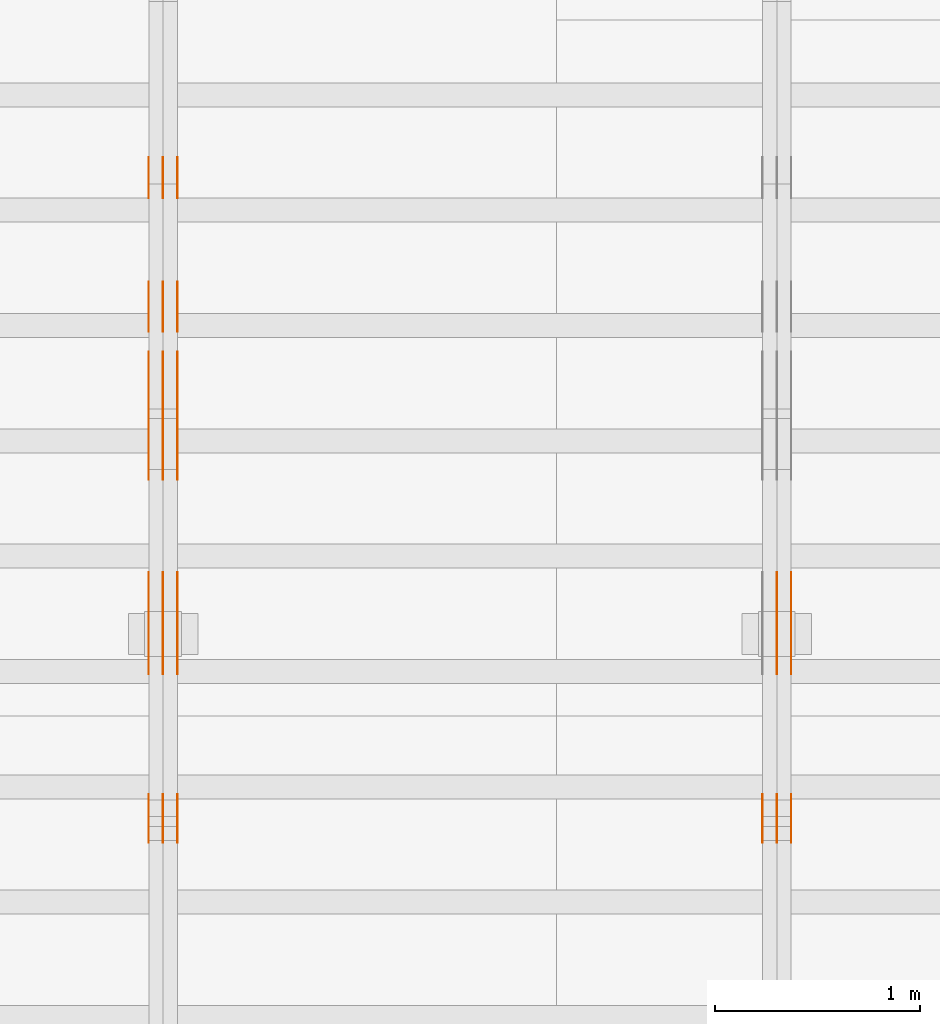
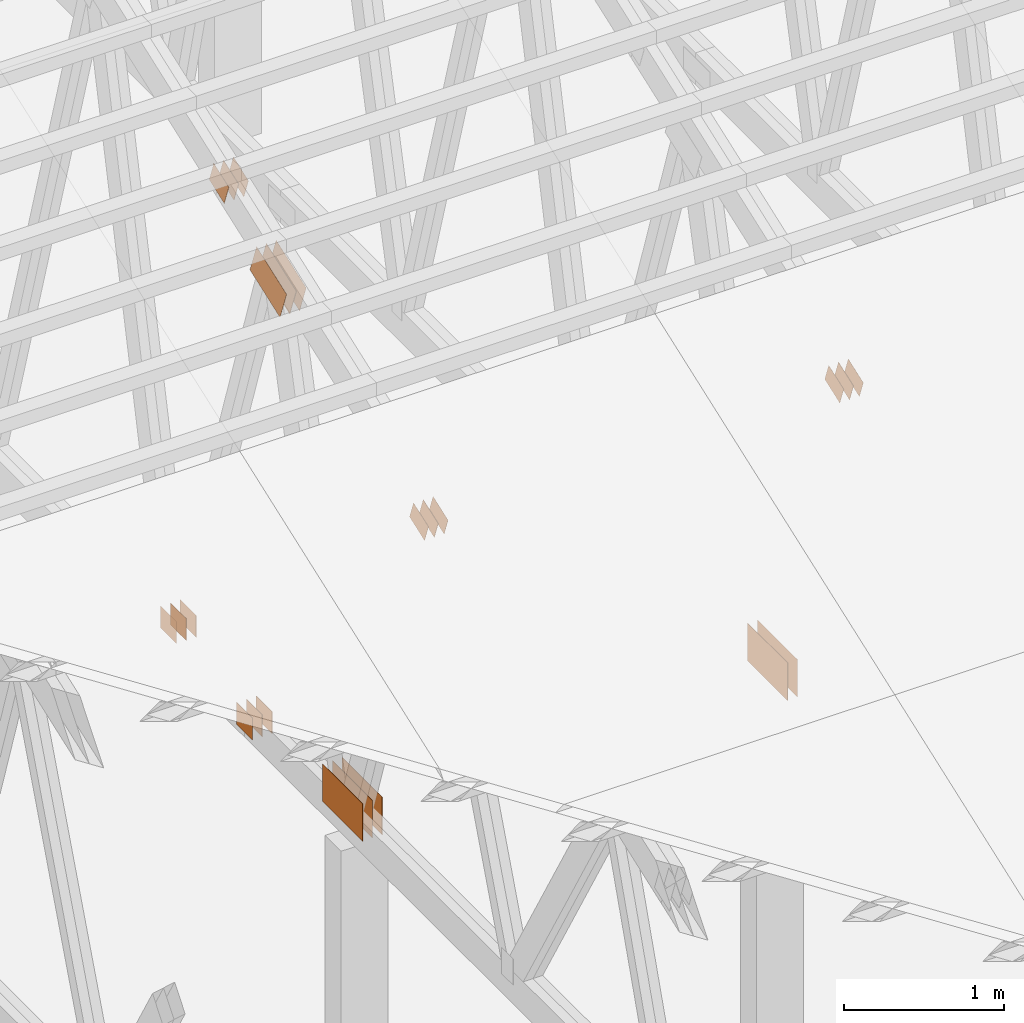
# One storey, part 81 of 189: 31 proxies.
"""IFC2X3 building model written with IfcOpenShell, lengths in millimetres."""

from ifc_helpers import new_model, entity, si_unit, converted_unit, derived_unit, direction, frame, frame_2d, origin, origin_2d_with_axis, place, context, subcontext, project, spatial, polyline, rectangle, outline, extrude, source, transform, mapped, material, type_object, type_shapes, element, save


model = new_model("IFC2X3")

# Units and contexts
model_context = context("Model", 3, precision=0.01, world=origin(), true_north=direction((6.12303176911189e-17, 1.0)))
body_context = subcontext(model_context, "Body", "Model", "MODEL_VIEW")
ifc_project = project(units=[si_unit("LENGTHUNIT", "METRE", prefix="MILLI"), si_unit("AREAUNIT", "SQUARE_METRE"), si_unit("VOLUMEUNIT", "CUBIC_METRE"), converted_unit("PLANEANGLEUNIT", "DEGREE", entity("IfcRatioMeasure", 0.0174532925199433), si_unit("PLANEANGLEUNIT", "RADIAN"), dimensions=[0, 0, 0, 0, 0, 0, 0]), si_unit("MASSUNIT", "GRAM", prefix="KILO"), derived_unit("MASSDENSITYUNIT", [(si_unit("MASSUNIT", "GRAM", prefix="KILO"), 1), (si_unit("LENGTHUNIT", "METRE"), -3)]), si_unit("TIMEUNIT", "SECOND"), si_unit("FREQUENCYUNIT", "HERTZ"), si_unit("THERMODYNAMICTEMPERATUREUNIT", "DEGREE_CELSIUS"), derived_unit("THERMALTRANSMITTANCEUNIT", [(si_unit("MASSUNIT", "GRAM", prefix="KILO"), 1), (si_unit("THERMODYNAMICTEMPERATUREUNIT", "KELVIN"), -1), (si_unit("TIMEUNIT", "SECOND"), -3)]), derived_unit("VOLUMETRICFLOWRATEUNIT", [(si_unit("LENGTHUNIT", "METRE"), 3), (si_unit("TIMEUNIT", "SECOND"), -1)]), si_unit("ELECTRICCURRENTUNIT", "AMPERE"), si_unit("ELECTRICVOLTAGEUNIT", "VOLT"), si_unit("POWERUNIT", "WATT"), si_unit("FORCEUNIT", "NEWTON"), si_unit("ILLUMINANCEUNIT", "LUX"), si_unit("LUMINOUSFLUXUNIT", "LUMEN"), si_unit("LUMINOUSINTENSITYUNIT", "CANDELA"), derived_unit("USERDEFINED", [(si_unit("MASSUNIT", "GRAM", prefix="KILO"), -1), (si_unit("LENGTHUNIT", "METRE"), -2), (si_unit("TIMEUNIT", "SECOND"), 3), (si_unit("LUMINOUSFLUXUNIT", "LUMEN"), 1)]), derived_unit("LINEARVELOCITYUNIT", [(si_unit("LENGTHUNIT", "METRE"), 1), (si_unit("TIMEUNIT", "SECOND"), -1)]), si_unit("PRESSUREUNIT", "PASCAL"), derived_unit("USERDEFINED", [(si_unit("LENGTHUNIT", "METRE"), -2), (si_unit("MASSUNIT", "GRAM", prefix="KILO"), 1), (si_unit("TIMEUNIT", "SECOND"), -2)])], contexts=[model_context])

# Site, building, storey
site_placement = place(None, origin())
site = spatial("IfcSite", under=ifc_project, at=site_placement, CompositionType="ELEMENT")
building_placement = place(site_placement, origin())
building = spatial("IfcBuilding", under=site, at=building_placement, CompositionType="ELEMENT")
storey_placement = place(building_placement, origin())
storey = spatial("IfcBuildingStorey", under=building, at=storey_placement, Name="Default", CompositionType="ELEMENT", Elevation=0.0)

# Proxies
ifc_material_1 = material(Name="IfcSurfaceStyle #76038")
building_element_proxy_type_1 = type_object("IfcBuildingElementProxyType", PredefinedType="NOTDEFINED", material=ifc_material_1)
shared_shape_1 = source(origin(), body_context, "Body", "SweptSolid", [
    extrude(rectangle(XDim=500.0, YDim=288.0, at=frame_2d((0.0, 1.4210854715202e-14), x_axis=(1.0, 0.0))), frame((250.000973740011, 144.0, 0.0), z_axis=(0.0, 0.0, 1.0), x_axis=(-1.0, 0.0, 0.0)), (0.0, 0.0, 1.0), 1.29999999999998),
])
type_shapes(building_element_proxy_type_1, [shared_shape_1])
proxy_1_placement = place(building_placement, frame((12301.3, 8551.90918250999, 389.0), z_axis=(-1.0, 0.0, 0.0), x_axis=(0.0, 1.0, 0.0)))
element("IfcBuildingElementProxy", 1, at=proxy_1_placement, inside=storey, type_object=building_element_proxy_type_1, material=ifc_material_1, context=body_context, shape_type="MappedRepresentation", body=[
    mapped(shared_shape_1, transform((0.0, 0.0, 0.0), scale=1.0)),
])
ifc_material_2 = material(Name="IfcSurfaceStyle #75981")
building_element_proxy_type_2 = type_object("IfcBuildingElementProxyType", PredefinedType="NOTDEFINED", material=ifc_material_2)
shared_shape_2 = source(origin(), body_context, "Body", "SweptSolid", [
    extrude(rectangle(XDim=500.0, YDim=288.0, at=frame_2d((0.0, 1.4210854715202e-14), x_axis=(1.0, 0.0))), frame((250.000973740011, 144.0, 0.0), z_axis=(0.0, 0.0, 1.0), x_axis=(-1.0, 0.0, 0.0)), (0.0, 0.0, 1.0), 1.29999999999997),
])
type_shapes(building_element_proxy_type_2, [shared_shape_2])
proxy_2_placement = place(building_placement, frame((12230.0, 8551.90918250999, 389.0), z_axis=(-1.0, 0.0, 0.0), x_axis=(0.0, 1.0, 0.0)))
element("IfcBuildingElementProxy", 2, at=proxy_2_placement, inside=storey, type_object=building_element_proxy_type_2, material=ifc_material_2, context=body_context, shape_type="MappedRepresentation", body=[
    mapped(shared_shape_2, transform((0.0, 0.0, 0.0), scale=1.0)),
])
ifc_material_3 = material(Name="IfcSurfaceStyle #75924")
building_element_proxy_type_3 = type_object("IfcBuildingElementProxyType", PredefinedType="NOTDEFINED", material=ifc_material_3)
shared_shape_3 = source(origin(), body_context, "Body", "SweptSolid", [
    extrude(rectangle(XDim=500.0, YDim=288.0, at=frame_2d((0.0, 1.4210854715202e-14), x_axis=(1.0, 0.0))), frame((250.000973740011, 144.0, 0.0), z_axis=(0.0, 0.0, 1.0), x_axis=(-1.0, 0.0, 0.0)), (0.0, 0.0, 1.0), 1.29999999999997),
])
type_shapes(building_element_proxy_type_3, [shared_shape_3])
proxy_3_placement = place(building_placement, frame((12231.3, 8551.90918250999, 389.0), z_axis=(-1.0, 0.0, 0.0), x_axis=(0.0, 1.0, 0.0)))
element("IfcBuildingElementProxy", 3, at=proxy_3_placement, inside=storey, type_object=building_element_proxy_type_3, material=ifc_material_3, context=body_context, shape_type="MappedRepresentation", body=[
    mapped(shared_shape_3, transform((0.0, 0.0, 0.0), scale=1.0)),
])
ifc_material_4 = material(Name="IfcSurfaceStyle #75810")
building_element_proxy_type_4 = type_object("IfcBuildingElementProxyType", PredefinedType="NOTDEFINED", material=ifc_material_4)
shared_shape_4 = source(origin(), body_context, "Body", "SweptSolid", [
    extrude(outline(polyline([(-100.00048713087, -72.0000025659129), (100.000394045495, -72.0000025659129), (99.9995694622958, 72.0000025659129), (-99.9994763769209, 72.0000025659128), (-100.00048713087, -72.0000025659129)])), frame((100.000394045495, 72.0000025659128, 0.0), z_axis=(0.0, 0.0, 1.0), x_axis=(-1.0, 0.0, 0.0)), (0.0, 0.0, 1.0), 1.3),
])
type_shapes(building_element_proxy_type_4, [shared_shape_4])
proxy_4_placement = place(building_placement, frame((12301.3, 7965.16887114408, 2936.19963864386), z_axis=(-1.0, 0.0, 0.0), x_axis=(0.0, -0.939692620785908, -0.342020143325669)))
element("IfcBuildingElementProxy", 4, at=proxy_4_placement, inside=storey, type_object=building_element_proxy_type_4, material=ifc_material_4, context=body_context, shape_type="MappedRepresentation", body=[
    mapped(shared_shape_4, transform((0.0, 0.0, 0.0), scale=1.0)),
])
ifc_material_5 = material(Name="IfcSurfaceStyle #75753")
building_element_proxy_type_5 = type_object("IfcBuildingElementProxyType", PredefinedType="NOTDEFINED", material=ifc_material_5)
shared_shape_5 = source(origin(), body_context, "Body", "SweptSolid", [
    extrude(outline(polyline([(-100.00048713087, -72.0000025659129), (100.000394045495, -72.0000025659129), (99.9995694622958, 72.0000025659129), (-99.9994763769209, 72.0000025659128), (-100.00048713087, -72.0000025659129)])), frame((100.000394045495, 72.0000025659128, 0.0), z_axis=(0.0, 0.0, 1.0), x_axis=(-1.0, 0.0, 0.0)), (0.0, 0.0, 1.0), 1.29999999999998),
])
type_shapes(building_element_proxy_type_5, [shared_shape_5])
proxy_5_placement = place(building_placement, frame((12230.0, 7965.16887114408, 2936.19963864386), z_axis=(-1.0, 0.0, 0.0), x_axis=(0.0, -0.939692620785908, -0.342020143325669)))
element("IfcBuildingElementProxy", 5, at=proxy_5_placement, inside=storey, type_object=building_element_proxy_type_5, material=ifc_material_5, context=body_context, shape_type="MappedRepresentation", body=[
    mapped(shared_shape_5, transform((0.0, 0.0, 0.0), scale=1.0)),
])
ifc_material_6 = material(Name="IfcSurfaceStyle #75696")
building_element_proxy_type_6 = type_object("IfcBuildingElementProxyType", PredefinedType="NOTDEFINED", material=ifc_material_6)
shared_shape_6 = source(origin(), body_context, "Body", "SweptSolid", [
    extrude(outline(polyline([(-100.00048713087, -72.0000025659129), (100.000394045495, -72.0000025659129), (99.9995694622958, 72.0000025659129), (-99.9994763769209, 72.0000025659128), (-100.00048713087, -72.0000025659129)])), frame((100.000394045495, 72.0000025659128, 0.0), z_axis=(0.0, 0.0, 1.0), x_axis=(-1.0, 0.0, 0.0)), (0.0, 0.0, 1.0), 1.29999999999998),
])
type_shapes(building_element_proxy_type_6, [shared_shape_6])
proxy_6_placement = place(building_placement, frame((12231.3, 7965.16887114408, 2936.19963864386), z_axis=(-1.0, 0.0, 0.0), x_axis=(0.0, -0.939692620785908, -0.342020143325669)))
element("IfcBuildingElementProxy", 6, at=proxy_6_placement, inside=storey, type_object=building_element_proxy_type_6, material=ifc_material_6, context=body_context, shape_type="MappedRepresentation", body=[
    mapped(shared_shape_6, transform((0.0, 0.0, 0.0), scale=1.0)),
])
ifc_material_7 = material(Name="IfcSurfaceStyle #75639")
building_element_proxy_type_7 = type_object("IfcBuildingElementProxyType", PredefinedType="NOTDEFINED", material=ifc_material_7)
shared_shape_7 = source(origin(), body_context, "Body", "SweptSolid", [
    extrude(outline(polyline([(-100.00048713087, -72.0000025659129), (100.000394045495, -72.0000025659129), (99.9995694622958, 72.0000025659129), (-99.9994763769209, 72.0000025659128), (-100.00048713087, -72.0000025659129)])), frame((100.000394045495, 72.0000025659128, 0.0), z_axis=(0.0, 0.0, 1.0), x_axis=(-1.0, 0.0, 0.0)), (0.0, 0.0, 1.0), 1.29999999999999),
])
type_shapes(building_element_proxy_type_7, [shared_shape_7])
proxy_7_placement = place(building_placement, frame((12160.0, 7965.16887114408, 2936.19963864386), z_axis=(-1.0, 0.0, 0.0), x_axis=(0.0, -0.939692620785908, -0.342020143325669)))
element("IfcBuildingElementProxy", 7, at=proxy_7_placement, inside=storey, type_object=building_element_proxy_type_7, material=ifc_material_7, context=body_context, shape_type="MappedRepresentation", body=[
    mapped(shared_shape_7, transform((0.0, 0.0, 0.0), scale=1.0)),
])
ifc_material_8 = material(Name="IfcSurfaceStyle #61160")
building_element_proxy_type_8 = type_object("IfcBuildingElementProxyType", PredefinedType="NOTDEFINED", material=ifc_material_8)
shared_shape_8 = source(origin(), body_context, "Body", "SweptSolid", [
    extrude(rectangle(XDim=200.0, YDim=168.0, at=origin_2d_with_axis()), frame((100.000765376775, 84.0, 0.0), z_axis=(0.0, 0.0, 1.0), x_axis=(-1.0, 0.0, 0.0)), (0.0, 0.0, 1.0), 1.3),
])
type_shapes(building_element_proxy_type_8, [shared_shape_8])
proxy_8_placement = place(building_placement, frame((9301.3, 10880.1574377482, 365.0), z_axis=(-1.0, 0.0, 0.0), x_axis=(0.0, 1.0, 0.0)))
element("IfcBuildingElementProxy", 8, at=proxy_8_placement, inside=storey, type_object=building_element_proxy_type_8, material=ifc_material_8, context=body_context, shape_type="MappedRepresentation", body=[
    mapped(shared_shape_8, transform((0.0, 0.0, 0.0), scale=1.0)),
])
ifc_material_9 = material(Name="IfcSurfaceStyle #61103")
building_element_proxy_type_9 = type_object("IfcBuildingElementProxyType", PredefinedType="NOTDEFINED", material=ifc_material_9)
shared_shape_9 = source(origin(), body_context, "Body", "SweptSolid", [
    extrude(rectangle(XDim=200.0, YDim=168.0, at=origin_2d_with_axis()), frame((100.000765376775, 84.0, 0.0), z_axis=(0.0, 0.0, 1.0), x_axis=(-1.0, 0.0, 0.0)), (0.0, 0.0, 1.0), 1.29999999999998),
])
type_shapes(building_element_proxy_type_9, [shared_shape_9])
proxy_9_placement = place(building_placement, frame((9230.0, 10880.1574377482, 365.0), z_axis=(-1.0, 0.0, 0.0), x_axis=(0.0, 1.0, 0.0)))
element("IfcBuildingElementProxy", 9, at=proxy_9_placement, inside=storey, type_object=building_element_proxy_type_9, material=ifc_material_9, context=body_context, shape_type="MappedRepresentation", body=[
    mapped(shared_shape_9, transform((0.0, 0.0, 0.0), scale=1.0)),
])
ifc_material_10 = material(Name="IfcSurfaceStyle #61046")
building_element_proxy_type_10 = type_object("IfcBuildingElementProxyType", PredefinedType="NOTDEFINED", material=ifc_material_10)
shared_shape_10 = source(origin(), body_context, "Body", "SweptSolid", [
    extrude(rectangle(XDim=200.0, YDim=168.0, at=origin_2d_with_axis()), frame((100.000765376775, 84.0, 0.0), z_axis=(0.0, 0.0, 1.0), x_axis=(-1.0, 0.0, 0.0)), (0.0, 0.0, 1.0), 1.29999999999998),
])
type_shapes(building_element_proxy_type_10, [shared_shape_10])
proxy_10_placement = place(building_placement, frame((9231.3, 10880.1574377482, 365.0), z_axis=(-1.0, 0.0, 0.0), x_axis=(0.0, 1.0, 0.0)))
element("IfcBuildingElementProxy", 10, at=proxy_10_placement, inside=storey, type_object=building_element_proxy_type_10, material=ifc_material_10, context=body_context, shape_type="MappedRepresentation", body=[
    mapped(shared_shape_10, transform((0.0, 0.0, 0.0), scale=1.0)),
])
ifc_material_11 = material(Name="IfcSurfaceStyle #60989")
building_element_proxy_type_11 = type_object("IfcBuildingElementProxyType", PredefinedType="NOTDEFINED", material=ifc_material_11)
shared_shape_11 = source(origin(), body_context, "Body", "SweptSolid", [
    extrude(rectangle(XDim=200.0, YDim=168.0, at=origin_2d_with_axis()), frame((100.000765376775, 84.0, 0.0), z_axis=(0.0, 0.0, 1.0), x_axis=(-1.0, 0.0, 0.0)), (0.0, 0.0, 1.0), 1.29999999999999),
])
type_shapes(building_element_proxy_type_11, [shared_shape_11])
proxy_11_placement = place(building_placement, frame((9160.0, 10880.1574377482, 365.0), z_axis=(-1.0, 0.0, 0.0), x_axis=(0.0, 1.0, 0.0)))
element("IfcBuildingElementProxy", 11, at=proxy_11_placement, inside=storey, type_object=building_element_proxy_type_11, material=ifc_material_11, context=body_context, shape_type="MappedRepresentation", body=[
    mapped(shared_shape_11, transform((0.0, 0.0, 0.0), scale=1.0)),
])
ifc_material_12 = material(Name="IfcSurfaceStyle #60932")
building_element_proxy_type_12 = type_object("IfcBuildingElementProxyType", PredefinedType="NOTDEFINED", material=ifc_material_12)
shared_shape_12 = source(origin(), body_context, "Body", "SweptSolid", [
    extrude(outline(polyline([(-199.999582244654, -119.99984375717), (200.000344770932, -119.99984375717), (199.999582244655, 119.99984375717), (-200.000344770934, 119.99984375717), (-199.999582244654, -119.99984375717)])), frame((200.000344770932, 120.0000091947, 0.0), z_axis=(0.0, 0.0, 1.0), x_axis=(-1.0, 0.0, 0.0)), (0.0, 0.0, 1.0), 1.29999999999999),
])
type_shapes(building_element_proxy_type_12, [shared_shape_12])
proxy_12_placement = place(building_placement, frame((9301.3, 9961.90704972973, 3612.2451494258), z_axis=(-1.0, 0.0, 0.0), x_axis=(0.0, -0.939692620785908, -0.342020143325669)))
element("IfcBuildingElementProxy", 12, at=proxy_12_placement, inside=storey, type_object=building_element_proxy_type_12, material=ifc_material_12, context=body_context, shape_type="MappedRepresentation", body=[
    mapped(shared_shape_12, transform((0.0, 0.0, 0.0), scale=1.0)),
])
ifc_material_13 = material(Name="IfcSurfaceStyle #60875")
building_element_proxy_type_13 = type_object("IfcBuildingElementProxyType", PredefinedType="NOTDEFINED", material=ifc_material_13)
shared_shape_13 = source(origin(), body_context, "Body", "SweptSolid", [
    extrude(outline(polyline([(-199.999582244654, -119.99984375717), (200.000344770932, -119.99984375717), (199.999582244655, 119.99984375717), (-200.000344770934, 119.99984375717), (-199.999582244654, -119.99984375717)])), frame((200.000344770932, 120.0000091947, 0.0), z_axis=(0.0, 0.0, 1.0), x_axis=(-1.0, 0.0, 0.0)), (0.0, 0.0, 1.0), 1.29999999999997),
])
type_shapes(building_element_proxy_type_13, [shared_shape_13])
proxy_13_placement = place(building_placement, frame((9230.0, 9961.90704972973, 3612.2451494258), z_axis=(-1.0, 0.0, 0.0), x_axis=(0.0, -0.939692620785908, -0.342020143325669)))
element("IfcBuildingElementProxy", 13, at=proxy_13_placement, inside=storey, type_object=building_element_proxy_type_13, material=ifc_material_13, context=body_context, shape_type="MappedRepresentation", body=[
    mapped(shared_shape_13, transform((0.0, 0.0, 0.0), scale=1.0)),
])
ifc_material_14 = material(Name="IfcSurfaceStyle #60818")
building_element_proxy_type_14 = type_object("IfcBuildingElementProxyType", PredefinedType="NOTDEFINED", material=ifc_material_14)
shared_shape_14 = source(origin(), body_context, "Body", "SweptSolid", [
    extrude(outline(polyline([(-199.999582244654, -119.99984375717), (200.000344770932, -119.99984375717), (199.999582244655, 119.99984375717), (-200.000344770934, 119.99984375717), (-199.999582244654, -119.99984375717)])), frame((200.000344770932, 120.0000091947, 0.0), z_axis=(0.0, 0.0, 1.0), x_axis=(-1.0, 0.0, 0.0)), (0.0, 0.0, 1.0), 1.29999999999997),
])
type_shapes(building_element_proxy_type_14, [shared_shape_14])
proxy_14_placement = place(building_placement, frame((9231.3, 9961.90704972973, 3612.2451494258), z_axis=(-1.0, 0.0, 0.0), x_axis=(0.0, -0.939692620785908, -0.342020143325669)))
element("IfcBuildingElementProxy", 14, at=proxy_14_placement, inside=storey, type_object=building_element_proxy_type_14, material=ifc_material_14, context=body_context, shape_type="MappedRepresentation", body=[
    mapped(shared_shape_14, transform((0.0, 0.0, 0.0), scale=1.0)),
])
ifc_material_15 = material(Name="IfcSurfaceStyle #60761")
building_element_proxy_type_15 = type_object("IfcBuildingElementProxyType", PredefinedType="NOTDEFINED", material=ifc_material_15)
shared_shape_15 = source(origin(), body_context, "Body", "SweptSolid", [
    extrude(outline(polyline([(-199.999582244654, -119.99984375717), (200.000344770932, -119.99984375717), (199.999582244655, 119.99984375717), (-200.000344770934, 119.99984375717), (-199.999582244654, -119.99984375717)])), frame((200.000344770932, 120.0000091947, 0.0), z_axis=(0.0, 0.0, 1.0), x_axis=(-1.0, 0.0, 0.0)), (0.0, 0.0, 1.0), 1.29999999999998),
])
type_shapes(building_element_proxy_type_15, [shared_shape_15])
proxy_15_placement = place(building_placement, frame((9160.0, 9961.90704972973, 3612.2451494258), z_axis=(-1.0, 0.0, 0.0), x_axis=(0.0, -0.939692620785908, -0.342020143325669)))
element("IfcBuildingElementProxy", 15, at=proxy_15_placement, inside=storey, type_object=building_element_proxy_type_15, material=ifc_material_15, context=body_context, shape_type="MappedRepresentation", body=[
    mapped(shared_shape_15, transform((0.0, 0.0, 0.0), scale=1.0)),
])
ifc_material_16 = material(Name="IfcSurfaceStyle #60248")
building_element_proxy_type_16 = type_object("IfcBuildingElementProxyType", PredefinedType="NOTDEFINED", material=ifc_material_16)
shared_shape_16 = source(origin(), body_context, "Body", "SweptSolid", [
    extrude(rectangle(XDim=500.0, YDim=288.0, at=frame_2d((0.0, 1.4210854715202e-14), x_axis=(1.0, 0.0))), frame((250.000973740011, 144.0, 0.0), z_axis=(0.0, 0.0, 1.0), x_axis=(-1.0, 0.0, 0.0)), (0.0, 0.0, 1.0), 1.29999999999998),
])
type_shapes(building_element_proxy_type_16, [shared_shape_16])
proxy_16_placement = place(building_placement, frame((9301.3, 8551.90918250999, 389.0), z_axis=(-1.0, 0.0, 0.0), x_axis=(0.0, 1.0, 0.0)))
element("IfcBuildingElementProxy", 16, at=proxy_16_placement, inside=storey, type_object=building_element_proxy_type_16, material=ifc_material_16, context=body_context, shape_type="MappedRepresentation", body=[
    mapped(shared_shape_16, transform((0.0, 0.0, 0.0), scale=1.0)),
])
ifc_material_17 = material(Name="IfcSurfaceStyle #60191")
building_element_proxy_type_17 = type_object("IfcBuildingElementProxyType", PredefinedType="NOTDEFINED", material=ifc_material_17)
shared_shape_17 = source(origin(), body_context, "Body", "SweptSolid", [
    extrude(rectangle(XDim=500.0, YDim=288.0, at=frame_2d((0.0, 1.4210854715202e-14), x_axis=(1.0, 0.0))), frame((250.000973740011, 144.0, 0.0), z_axis=(0.0, 0.0, 1.0), x_axis=(-1.0, 0.0, 0.0)), (0.0, 0.0, 1.0), 1.29999999999997),
])
type_shapes(building_element_proxy_type_17, [shared_shape_17])
proxy_17_placement = place(building_placement, frame((9230.0, 8551.90918250999, 389.0), z_axis=(-1.0, 0.0, 0.0), x_axis=(0.0, 1.0, 0.0)))
element("IfcBuildingElementProxy", 17, at=proxy_17_placement, inside=storey, type_object=building_element_proxy_type_17, material=ifc_material_17, context=body_context, shape_type="MappedRepresentation", body=[
    mapped(shared_shape_17, transform((0.0, 0.0, 0.0), scale=1.0)),
])
ifc_material_18 = material(Name="IfcSurfaceStyle #60134")
building_element_proxy_type_18 = type_object("IfcBuildingElementProxyType", PredefinedType="NOTDEFINED", material=ifc_material_18)
shared_shape_18 = source(origin(), body_context, "Body", "SweptSolid", [
    extrude(rectangle(XDim=500.0, YDim=288.0, at=frame_2d((0.0, 1.4210854715202e-14), x_axis=(1.0, 0.0))), frame((250.000973740011, 144.0, 0.0), z_axis=(0.0, 0.0, 1.0), x_axis=(-1.0, 0.0, 0.0)), (0.0, 0.0, 1.0), 1.29999999999997),
])
type_shapes(building_element_proxy_type_18, [shared_shape_18])
proxy_18_placement = place(building_placement, frame((9231.3, 8551.90918250999, 389.0), z_axis=(-1.0, 0.0, 0.0), x_axis=(0.0, 1.0, 0.0)))
element("IfcBuildingElementProxy", 18, at=proxy_18_placement, inside=storey, type_object=building_element_proxy_type_18, material=ifc_material_18, context=body_context, shape_type="MappedRepresentation", body=[
    mapped(shared_shape_18, transform((0.0, 0.0, 0.0), scale=1.0)),
])
ifc_material_19 = material(Name="IfcSurfaceStyle #60077")
building_element_proxy_type_19 = type_object("IfcBuildingElementProxyType", PredefinedType="NOTDEFINED", material=ifc_material_19)
shared_shape_19 = source(origin(), body_context, "Body", "SweptSolid", [
    extrude(rectangle(XDim=500.0, YDim=288.0, at=frame_2d((0.0, 1.4210854715202e-14), x_axis=(1.0, 0.0))), frame((250.000973740011, 144.0, 0.0), z_axis=(0.0, 0.0, 1.0), x_axis=(-1.0, 0.0, 0.0)), (0.0, 0.0, 1.0), 1.29999999999997),
])
type_shapes(building_element_proxy_type_19, [shared_shape_19])
proxy_19_placement = place(building_placement, frame((9160.0, 8551.90918250999, 389.0), z_axis=(-1.0, 0.0, 0.0), x_axis=(0.0, 1.0, 0.0)))
element("IfcBuildingElementProxy", 19, at=proxy_19_placement, inside=storey, type_object=building_element_proxy_type_19, material=ifc_material_19, context=body_context, shape_type="MappedRepresentation", body=[
    mapped(shared_shape_19, transform((0.0, 0.0, 0.0), scale=1.0)),
])
ifc_material_20 = material(Name="IfcSurfaceStyle #60020")
building_element_proxy_type_20 = type_object("IfcBuildingElementProxyType", PredefinedType="NOTDEFINED", material=ifc_material_20)
shared_shape_20 = source(origin(), body_context, "Body", "SweptSolid", [
    extrude(outline(polyline([(-100.00048713087, -72.0000025659129), (100.000394045495, -72.0000025659129), (99.9995694622958, 72.0000025659129), (-99.9994763769209, 72.0000025659128), (-100.00048713087, -72.0000025659129)])), frame((100.000394045495, 72.0000025659128, 0.0), z_axis=(0.0, 0.0, 1.0), x_axis=(-1.0, 0.0, 0.0)), (0.0, 0.0, 1.0), 1.3),
])
type_shapes(building_element_proxy_type_20, [shared_shape_20])
proxy_20_placement = place(building_placement, frame((9301.3, 7965.16887114408, 2936.19963864386), z_axis=(-1.0, 0.0, 0.0), x_axis=(0.0, -0.939692620785908, -0.342020143325669)))
element("IfcBuildingElementProxy", 20, at=proxy_20_placement, inside=storey, type_object=building_element_proxy_type_20, material=ifc_material_20, context=body_context, shape_type="MappedRepresentation", body=[
    mapped(shared_shape_20, transform((0.0, 0.0, 0.0), scale=1.0)),
])
ifc_material_21 = material(Name="IfcSurfaceStyle #59963")
building_element_proxy_type_21 = type_object("IfcBuildingElementProxyType", PredefinedType="NOTDEFINED", material=ifc_material_21)
shared_shape_21 = source(origin(), body_context, "Body", "SweptSolid", [
    extrude(outline(polyline([(-100.00048713087, -72.0000025659129), (100.000394045495, -72.0000025659129), (99.9995694622958, 72.0000025659129), (-99.9994763769209, 72.0000025659128), (-100.00048713087, -72.0000025659129)])), frame((100.000394045495, 72.0000025659128, 0.0), z_axis=(0.0, 0.0, 1.0), x_axis=(-1.0, 0.0, 0.0)), (0.0, 0.0, 1.0), 1.29999999999998),
])
type_shapes(building_element_proxy_type_21, [shared_shape_21])
proxy_21_placement = place(building_placement, frame((9230.0, 7965.16887114408, 2936.19963864386), z_axis=(-1.0, 0.0, 0.0), x_axis=(0.0, -0.939692620785908, -0.342020143325669)))
element("IfcBuildingElementProxy", 21, at=proxy_21_placement, inside=storey, type_object=building_element_proxy_type_21, material=ifc_material_21, context=body_context, shape_type="MappedRepresentation", body=[
    mapped(shared_shape_21, transform((0.0, 0.0, 0.0), scale=1.0)),
])
ifc_material_22 = material(Name="IfcSurfaceStyle #59906")
building_element_proxy_type_22 = type_object("IfcBuildingElementProxyType", PredefinedType="NOTDEFINED", material=ifc_material_22)
shared_shape_22 = source(origin(), body_context, "Body", "SweptSolid", [
    extrude(outline(polyline([(-100.00048713087, -72.0000025659129), (100.000394045495, -72.0000025659129), (99.9995694622958, 72.0000025659129), (-99.9994763769209, 72.0000025659128), (-100.00048713087, -72.0000025659129)])), frame((100.000394045495, 72.0000025659128, 0.0), z_axis=(0.0, 0.0, 1.0), x_axis=(-1.0, 0.0, 0.0)), (0.0, 0.0, 1.0), 1.29999999999998),
])
type_shapes(building_element_proxy_type_22, [shared_shape_22])
proxy_22_placement = place(building_placement, frame((9231.3, 7965.16887114408, 2936.19963864386), z_axis=(-1.0, 0.0, 0.0), x_axis=(0.0, -0.939692620785908, -0.342020143325669)))
element("IfcBuildingElementProxy", 22, at=proxy_22_placement, inside=storey, type_object=building_element_proxy_type_22, material=ifc_material_22, context=body_context, shape_type="MappedRepresentation", body=[
    mapped(shared_shape_22, transform((0.0, 0.0, 0.0), scale=1.0)),
])
ifc_material_23 = material(Name="IfcSurfaceStyle #59849")
building_element_proxy_type_23 = type_object("IfcBuildingElementProxyType", PredefinedType="NOTDEFINED", material=ifc_material_23)
shared_shape_23 = source(origin(), body_context, "Body", "SweptSolid", [
    extrude(outline(polyline([(-100.00048713087, -72.0000025659129), (100.000394045495, -72.0000025659129), (99.9995694622958, 72.0000025659129), (-99.9994763769209, 72.0000025659128), (-100.00048713087, -72.0000025659129)])), frame((100.000394045495, 72.0000025659128, 0.0), z_axis=(0.0, 0.0, 1.0), x_axis=(-1.0, 0.0, 0.0)), (0.0, 0.0, 1.0), 1.29999999999999),
])
type_shapes(building_element_proxy_type_23, [shared_shape_23])
proxy_23_placement = place(building_placement, frame((9160.0, 7965.16887114408, 2936.19963864386), z_axis=(-1.0, 0.0, 0.0), x_axis=(0.0, -0.939692620785908, -0.342020143325669)))
element("IfcBuildingElementProxy", 23, at=proxy_23_placement, inside=storey, type_object=building_element_proxy_type_23, material=ifc_material_23, context=body_context, shape_type="MappedRepresentation", body=[
    mapped(shared_shape_23, transform((0.0, 0.0, 0.0), scale=1.0)),
])
ifc_material_24 = material(Name="IfcSurfaceStyle #54608")
building_element_proxy_type_24 = type_object("IfcBuildingElementProxyType", PredefinedType="NOTDEFINED", material=ifc_material_24)
shared_shape_24 = source(origin(), body_context, "Body", "SweptSolid", [
    extrude(rectangle(XDim=200.0, YDim=168.0, at=origin_2d_with_axis()), frame((100.0, 84.0, 0.0), z_axis=(0.0, 0.0, 1.0), x_axis=(-1.0, 0.0, 0.0)), (0.0, 0.0, 1.0), 1.3),
])
type_shapes(building_element_proxy_type_24, [shared_shape_24])
proxy_24_placement = place(building_placement, frame((9301.3, 9929.23046875, 206.5), z_axis=(-1.0, 0.0, 0.0), x_axis=(0.0, 1.0, 0.0)))
element("IfcBuildingElementProxy", 24, at=proxy_24_placement, inside=storey, type_object=building_element_proxy_type_24, material=ifc_material_24, context=body_context, shape_type="MappedRepresentation", body=[
    mapped(shared_shape_24, transform((0.0, 0.0, 0.0), scale=1.0)),
])
ifc_material_25 = material(Name="IfcSurfaceStyle #54551")
building_element_proxy_type_25 = type_object("IfcBuildingElementProxyType", PredefinedType="NOTDEFINED", material=ifc_material_25)
shared_shape_25 = source(origin(), body_context, "Body", "SweptSolid", [
    extrude(rectangle(XDim=200.0, YDim=168.0, at=origin_2d_with_axis()), frame((100.0, 84.0, 0.0), z_axis=(0.0, 0.0, 1.0), x_axis=(-1.0, 0.0, 0.0)), (0.0, 0.0, 1.0), 1.29999999999998),
])
type_shapes(building_element_proxy_type_25, [shared_shape_25])
proxy_25_placement = place(building_placement, frame((9230.0, 9929.23046875, 206.5), z_axis=(-1.0, 0.0, 0.0), x_axis=(0.0, 1.0, 0.0)))
element("IfcBuildingElementProxy", 25, at=proxy_25_placement, inside=storey, type_object=building_element_proxy_type_25, material=ifc_material_25, context=body_context, shape_type="MappedRepresentation", body=[
    mapped(shared_shape_25, transform((0.0, 0.0, 0.0), scale=1.0)),
])
ifc_material_26 = material(Name="IfcSurfaceStyle #54494")
building_element_proxy_type_26 = type_object("IfcBuildingElementProxyType", PredefinedType="NOTDEFINED", material=ifc_material_26)
shared_shape_26 = source(origin(), body_context, "Body", "SweptSolid", [
    extrude(rectangle(XDim=200.0, YDim=168.0, at=origin_2d_with_axis()), frame((100.0, 84.0, 0.0), z_axis=(0.0, 0.0, 1.0), x_axis=(-1.0, 0.0, 0.0)), (0.0, 0.0, 1.0), 1.29999999999998),
])
type_shapes(building_element_proxy_type_26, [shared_shape_26])
proxy_26_placement = place(building_placement, frame((9231.3, 9929.23046875, 206.5), z_axis=(-1.0, 0.0, 0.0), x_axis=(0.0, 1.0, 0.0)))
element("IfcBuildingElementProxy", 26, at=proxy_26_placement, inside=storey, type_object=building_element_proxy_type_26, material=ifc_material_26, context=body_context, shape_type="MappedRepresentation", body=[
    mapped(shared_shape_26, transform((0.0, 0.0, 0.0), scale=1.0)),
])
ifc_material_27 = material(Name="IfcSurfaceStyle #54437")
building_element_proxy_type_27 = type_object("IfcBuildingElementProxyType", PredefinedType="NOTDEFINED", material=ifc_material_27)
shared_shape_27 = source(origin(), body_context, "Body", "SweptSolid", [
    extrude(rectangle(XDim=200.0, YDim=168.0, at=origin_2d_with_axis()), frame((100.0, 84.0, 0.0), z_axis=(0.0, 0.0, 1.0), x_axis=(-1.0, 0.0, 0.0)), (0.0, 0.0, 1.0), 1.29999999999999),
])
type_shapes(building_element_proxy_type_27, [shared_shape_27])
proxy_27_placement = place(building_placement, frame((9160.0, 9929.23046875, 206.5), z_axis=(-1.0, 0.0, 0.0), x_axis=(0.0, 1.0, 0.0)))
element("IfcBuildingElementProxy", 27, at=proxy_27_placement, inside=storey, type_object=building_element_proxy_type_27, material=ifc_material_27, context=body_context, shape_type="MappedRepresentation", body=[
    mapped(shared_shape_27, transform((0.0, 0.0, 0.0), scale=1.0)),
])
ifc_material_28 = material(Name="IfcSurfaceStyle #53528")
building_element_proxy_type_28 = type_object("IfcBuildingElementProxyType", PredefinedType="NOTDEFINED", material=ifc_material_28)
shared_shape_28 = source(origin(), body_context, "Body", "SweptSolid", [
    extrude(outline(polyline([(-100.00072430513, -84.0000258989549), (100.000156871239, -84.0000258989549), (99.9997648860508, 84.0000258989549), (-99.9991974521591, 84.0000258989548), (-100.00072430513, -84.0000258989549)])), frame((100.000156871239, 84.0000258989548, 0.0), z_axis=(0.0, 0.0, 1.0), x_axis=(-1.0, 0.0, 0.0)), (0.0, 0.0, 1.0), 1.3),
])
type_shapes(building_element_proxy_type_28, [shared_shape_28])
proxy_28_placement = place(building_placement, frame((9301.3, 10226.4409888304, 4081.14941482552), z_axis=(-1.0, 0.0, 0.0), x_axis=(0.0, 0.939692620785908, 0.342020143325669)))
element("IfcBuildingElementProxy", 28, at=proxy_28_placement, inside=storey, type_object=building_element_proxy_type_28, material=ifc_material_28, context=body_context, shape_type="MappedRepresentation", body=[
    mapped(shared_shape_28, transform((0.0, 0.0, 0.0), scale=1.0)),
])
ifc_material_29 = material(Name="IfcSurfaceStyle #53471")
building_element_proxy_type_29 = type_object("IfcBuildingElementProxyType", PredefinedType="NOTDEFINED", material=ifc_material_29)
shared_shape_29 = source(origin(), body_context, "Body", "SweptSolid", [
    extrude(outline(polyline([(-100.00072430513, -84.0000258989549), (100.000156871239, -84.0000258989549), (99.9997648860508, 84.0000258989549), (-99.9991974521591, 84.0000258989548), (-100.00072430513, -84.0000258989549)])), frame((100.000156871239, 84.0000258989548, 0.0), z_axis=(0.0, 0.0, 1.0), x_axis=(-1.0, 0.0, 0.0)), (0.0, 0.0, 1.0), 1.29999999999998),
])
type_shapes(building_element_proxy_type_29, [shared_shape_29])
proxy_29_placement = place(building_placement, frame((9230.0, 10226.4409888304, 4081.14941482552), z_axis=(-1.0, 0.0, 0.0), x_axis=(0.0, 0.939692620785908, 0.342020143325669)))
element("IfcBuildingElementProxy", 29, at=proxy_29_placement, inside=storey, type_object=building_element_proxy_type_29, material=ifc_material_29, context=body_context, shape_type="MappedRepresentation", body=[
    mapped(shared_shape_29, transform((0.0, 0.0, 0.0), scale=1.0)),
])
ifc_material_30 = material(Name="IfcSurfaceStyle #53414")
building_element_proxy_type_30 = type_object("IfcBuildingElementProxyType", PredefinedType="NOTDEFINED", material=ifc_material_30)
shared_shape_30 = source(origin(), body_context, "Body", "SweptSolid", [
    extrude(outline(polyline([(-100.00072430513, -84.0000258989549), (100.000156871239, -84.0000258989549), (99.9997648860508, 84.0000258989549), (-99.9991974521591, 84.0000258989548), (-100.00072430513, -84.0000258989549)])), frame((100.000156871239, 84.0000258989548, 0.0), z_axis=(0.0, 0.0, 1.0), x_axis=(-1.0, 0.0, 0.0)), (0.0, 0.0, 1.0), 1.29999999999998),
])
type_shapes(building_element_proxy_type_30, [shared_shape_30])
proxy_30_placement = place(building_placement, frame((9231.3, 10226.4409888304, 4081.14941482552), z_axis=(-1.0, 0.0, 0.0), x_axis=(0.0, 0.939692620785908, 0.342020143325669)))
element("IfcBuildingElementProxy", 30, at=proxy_30_placement, inside=storey, type_object=building_element_proxy_type_30, material=ifc_material_30, context=body_context, shape_type="MappedRepresentation", body=[
    mapped(shared_shape_30, transform((0.0, 0.0, 0.0), scale=1.0)),
])
ifc_material_31 = material(Name="IfcSurfaceStyle #53357")
building_element_proxy_type_31 = type_object("IfcBuildingElementProxyType", PredefinedType="NOTDEFINED", material=ifc_material_31)
shared_shape_31 = source(origin(), body_context, "Body", "SweptSolid", [
    extrude(outline(polyline([(-100.00072430513, -84.0000258989549), (100.000156871239, -84.0000258989549), (99.9997648860508, 84.0000258989549), (-99.9991974521591, 84.0000258989548), (-100.00072430513, -84.0000258989549)])), frame((100.000156871239, 84.0000258989548, 0.0), z_axis=(0.0, 0.0, 1.0), x_axis=(-1.0, 0.0, 0.0)), (0.0, 0.0, 1.0), 1.29999999999999),
])
type_shapes(building_element_proxy_type_31, [shared_shape_31])
proxy_31_placement = place(building_placement, frame((9160.0, 10226.4409888304, 4081.14941482552), z_axis=(-1.0, 0.0, 0.0), x_axis=(0.0, 0.939692620785908, 0.342020143325669)))
element("IfcBuildingElementProxy", 31, at=proxy_31_placement, inside=storey, type_object=building_element_proxy_type_31, material=ifc_material_31, context=body_context, shape_type="MappedRepresentation", body=[
    mapped(shared_shape_31, transform((0.0, 0.0, 0.0), scale=1.0)),
])

save(model, "model.ifc")
